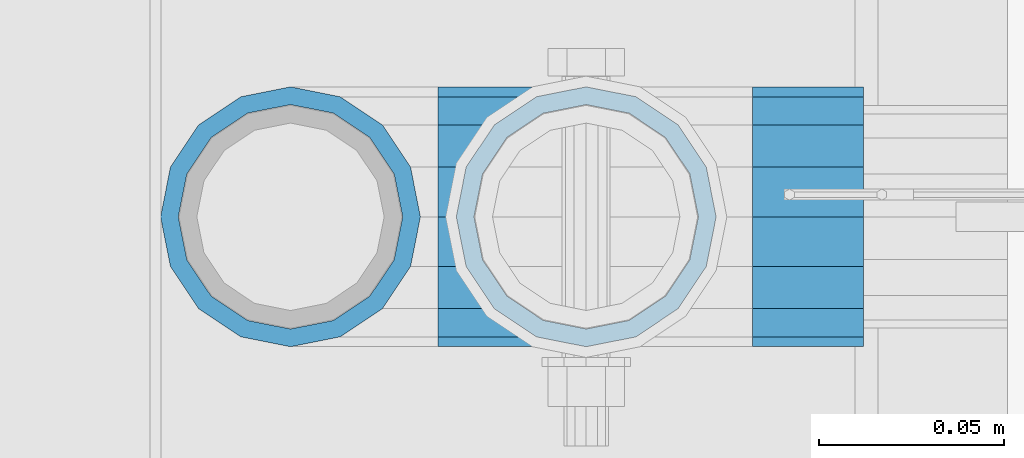
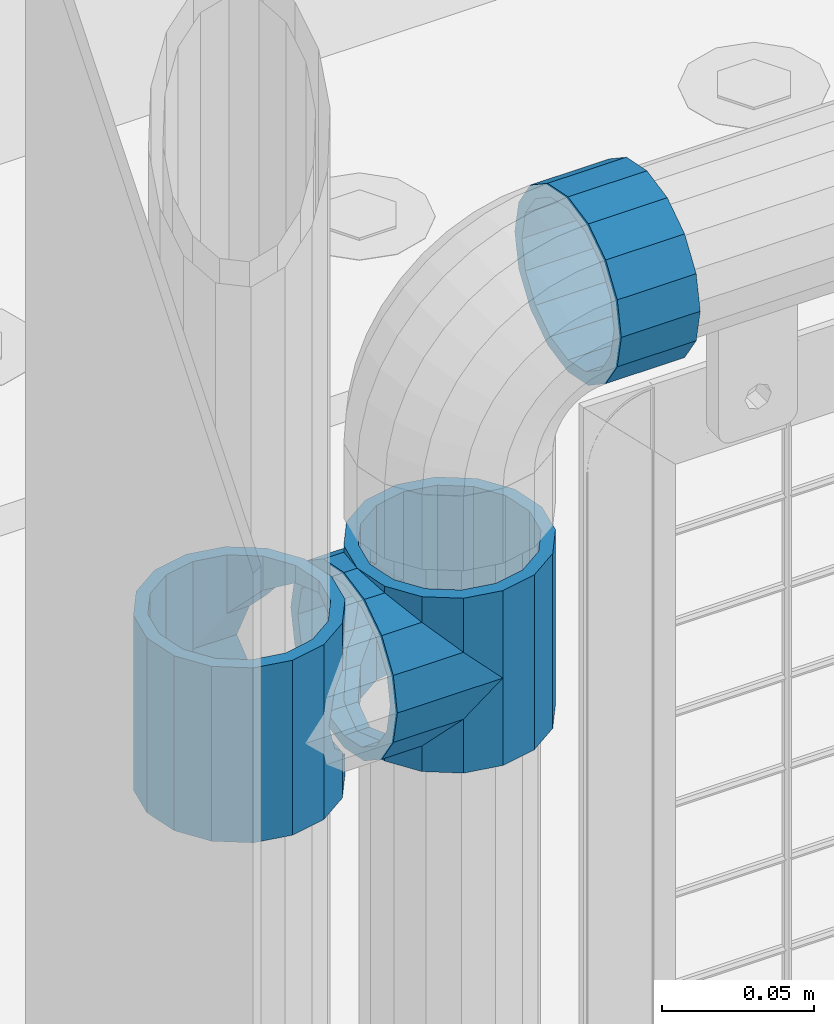
# One storey, part 134 of 219: 4 beams.
"""IFC2X3 building model written with IfcOpenShell, lengths in millimetres."""

from ifc_helpers import new_model, si_unit, frame, origin_with_axes, place, context, subcontext, project, spatial, faceted_brep, material, type_object, element, save


model = new_model("IFC2X3")

# Units and contexts
model_context = context("Model", 3, precision=1e-05, world=origin_with_axes())
body_context = subcontext(model_context, "Body", "Model", "MODEL_VIEW")
ifc_project = project(units=[si_unit("LENGTHUNIT", "METRE", prefix="MILLI"), si_unit("AREAUNIT", "SQUARE_METRE"), si_unit("VOLUMEUNIT", "CUBIC_METRE"), si_unit("MASSUNIT", "GRAM", prefix="KILO"), si_unit("TIMEUNIT", "SECOND"), si_unit("PLANEANGLEUNIT", "RADIAN"), si_unit("SOLIDANGLEUNIT", "STERADIAN"), si_unit("THERMODYNAMICTEMPERATUREUNIT", "DEGREE_CELSIUS"), si_unit("LUMINOUSINTENSITYUNIT", "LUMEN")], contexts=[model_context])

# Site, building, storey
site_placement = place(None, origin_with_axes())
site = spatial("IfcSite", under=ifc_project, at=site_placement, CompositionType="ELEMENT")
building_placement = place(site_placement, origin_with_axes())
building = spatial("IfcBuilding", under=site, at=building_placement, Name="Standard", CompositionType="ELEMENT")
storey_placement = place(building_placement, origin_with_axes())
storey = spatial("IfcBuildingStorey", under=building, at=storey_placement, Name="Undefined", CompositionType="ELEMENT", Elevation=0.0)

# Beams
ifc_material = material(Name="Misc_Undefined")
beam_type = type_object("IfcBeamType", PredefinedType="NOTDEFINED")
beam_1_placement = place(storey_placement, frame((621.0, 31664.5, 848.670000000001), z_axis=(0.0, 1.0, 0.0), x_axis=(-1.0, 0.0, 0.0)))
element("IfcBeam", 1, at=beam_1_placement, inside=storey, type_object=beam_type, material=ifc_material, context=body_context, shape_type="Brep", body=[
    faceted_brep([(0.0, 0.0, -35.1500000000015), (13.4513226476338, -13.4513226476329, -32.4743655677703), (13.4513226476338, 13.4513226476329, -32.4743655677703), (27.1226768591096, -21.4606908090117, 21.46069080901), (32.4743655677721, -26.8123795176755, 13.4513226476338), (32.4743655677721, -32.4743655677717, 13.4513226476338), (24.8548033587067, -24.8548033587072, 24.8548033587067), (24.8548033587067, -16.3810424080013, 24.8548033587067), (32.8397438117172, -28.0397438117175, 11.614442172282), (35.1499999999996, -30.35, 0.0), (35.1499999999996, -35.15, 0.0), (32.4743655677721, -26.8123795176712, -13.4513226476338), (32.4743655677721, -32.4743655677717, -13.4513226476338), (32.8397438117172, -28.0397438117175, -11.614442172282), (24.8548033587067, -16.3810424080013, -24.8548033587067), (24.8548033587067, -24.8548033587072, -24.8548033587067), (27.1226768591077, -21.4606908090117, -21.46069080901), (20.0882031229739, -11.6144421722805, -28.0397438117179), (16.6306603983649, 0.0, -30.3499999999985), (20.0882031229739, 11.6144421722805, -28.0397438117179), (24.8548033587067, 16.3810424080013, -24.8548033587067), (24.8548033587067, 24.8548033587072, -24.8548033587067), (27.1226768591077, 21.4606908090117, -21.46069080901), (32.4743655677721, 26.8123795176755, -13.4513226476338), (32.4743655677721, 32.4743655677717, -13.4513226476338), (32.8397438117172, 28.0397438117175, -11.614442172282), (35.1499999999996, 30.35, 0.0), (35.1499999999996, 35.15, 0.0), (32.8397438117172, 28.0397438117175, 11.614442172282), (32.4743655677721, 26.8123795176755, 13.4513226476338), (32.4743655677721, 32.4743655677717, 13.4513226476338), (27.1226768591096, 21.4606908090117, 21.46069080901), (24.8548033587067, 16.3810424080078, 24.8548033587067), (24.8548033587067, 24.8548033587072, 24.8548033587067), (0.0, 0.0, 35.1500000000015), (13.4513226476338, 13.4513226476329, 32.4743655677703), (13.4513226476338, -13.4513226476329, 32.4743655677703), (20.0882031229849, 11.6144421722805, 28.0397438117179), (16.6306603983739, 0.0, 30.3499999999985), (20.0882031229849, -11.6144421722805, 28.0397438117179), (40.1500000000015, -35.15, 0.0), (40.1500000000015, -32.4743655677717, 13.4513226476338), (40.1500000000015, -24.8548033587072, 24.8548033587067), (40.1500000000015, -13.4513226476329, 32.4743655677703), (40.1500000000015, 0.0, 35.1500000000015), (40.1500000000015, -24.8548033587072, -24.8548033587067), (40.1500000000015, -32.4743655677717, -13.4513226476338), (40.1500000000015, -13.4513226476329, -32.4743655677703), (40.1500000000015, 0.0, -35.1500000000015), (40.1500000000015, 13.4513226476329, -32.4743655677703), (40.1500000000015, 24.8548033587072, -24.8548033587067), (40.1500000000015, 32.4743655677717, -13.4513226476338), (40.1500000000015, 35.15, 0.0), (40.1500000000015, 32.4743655677717, 13.4513226476338), (40.1500000000015, 24.8548033587072, 24.8548033587067), (40.1500000000015, 13.4513226476329, 32.4743655677703), (40.1500000000015, -21.4606908090117, 21.46069080901), (40.1500000000015, -11.6144421722805, 28.0397438117179), (40.1500000000015, 0.0, 30.3499999999985), (40.1500000000015, 11.6144421722805, 28.0397438117179), (40.1500000000015, 21.4606908090117, 21.46069080901), (40.1500000000015, 28.0397438117175, 11.614442172282), (40.1500000000015, 30.35, 0.0), (40.1500000000015, 28.0397438117175, -11.614442172282), (40.1500000000015, 21.4606908090117, -21.46069080901), (40.1500000000015, 11.6144421722805, -28.0397438117179), (40.1500000000015, 0.0, -30.3499999999985), (40.1500000000015, -11.6144421722805, -28.0397438117179), (40.1500000000015, -21.4606908090117, -21.46069080901), (40.1500000000015, -28.0397438117175, -11.614442172282), (40.1500000000015, -30.35, 0.0), (40.1500000000015, -28.0397438117175, 11.614442172282)], [[[0, 1, 2]], [[3, 4, 5, 6, 7]], [[8, 9, 10, 5, 4]], [[11, 12, 10, 9, 13]], [[14, 15, 12, 11, 16]], [[2, 1, 15, 14, 17, 18, 19, 20, 21]], [[21, 20, 22, 23, 24]], [[24, 23, 25, 26, 27]], [[27, 26, 28, 29, 30]], [[30, 29, 31, 32, 33]], [[34, 35, 36]], [[33, 32, 37, 38, 39, 7, 6, 36, 35]], [[40, 41, 5, 10]], [[41, 42, 6, 5]], [[42, 43, 36, 6]], [[43, 44, 34, 36]], [[45, 46, 12, 15]], [[47, 45, 15, 1]], [[48, 47, 1, 0]], [[49, 48, 0, 2]], [[50, 49, 2, 21]], [[51, 50, 21, 24]], [[52, 51, 24, 27]], [[53, 52, 27, 30]], [[54, 53, 30, 33]], [[55, 54, 33, 35]], [[44, 55, 35, 34]], [[46, 40, 10, 12]], [[45, 47, 48, 49, 50, 51, 52, 53, 54, 55, 44, 43, 42, 41, 40, 46], [56, 57, 58, 59, 60, 61, 62, 63, 64, 65, 66, 67, 68, 69, 70, 71]], [[59, 58, 38, 37]], [[60, 59, 37, 32, 31]], [[61, 60, 31, 29, 28]], [[62, 61, 28, 26]], [[63, 62, 26, 25]], [[22, 64, 63, 25, 23]], [[19, 65, 64, 22, 20]], [[66, 65, 19, 18]], [[67, 66, 18, 17]], [[68, 67, 17, 14, 16]], [[69, 68, 16, 11, 13]], [[70, 69, 13, 9]], [[71, 70, 9, 8]], [[3, 56, 71, 8, 4]], [[39, 57, 56, 3, 7]], [[58, 57, 39, 38]]]),
])
beam_2_placement = place(storey_placement, frame((541.0, 31664.5, 883.820000000001), z_axis=(-1.0, 0.0, 0.0), x_axis=(0.0, 0.0, -1.0)))
element("IfcBeam", 2, at=beam_2_placement, inside=storey, type_object=beam_type, material=ifc_material, context=body_context, shape_type="Brep", body=[
    faceted_brep([(13.6893091909879, -21.46069080901, -21.4606908090118), (13.6893091909879, -21.46069080901, -27.1226768591077), (8.33762048232455, -13.4513226476338, -32.4743655677721), (7.11025618828211, -11.614442172282, -32.839743811719), (7.11025618828211, -11.614442172282, -28.0397438117179), (23.5355578277191, -28.0397438117179, -11.6144421722802), (23.5355578277191, -28.0397438117179, -20.0882031229739), (18.7689575919921, -24.8548033587067, -24.8548033587067), (35.1499999999996, -30.35, 0.0), (35.1499999999996, -30.3499999999985, -16.6306603983649), (46.7644421722801, -28.0397438117179, -11.6144421722802), (46.7644421722801, -28.0397438117179, -20.0882031229739), (56.6106908090114, -21.46069080901, -21.4606908090118), (56.6106908090114, -21.46069080901, -27.1226768591077), (51.5310424080006, -24.8548033587067, -24.8548033587067), (63.1897438117172, -11.614442172282, -28.0397438117179), (63.1897438117172, -11.614442172282, -32.839743811719), (61.9623795176747, -13.4513226476338, -32.4743655677721), (65.4999999999997, 0.0, -30.3500000000004), (65.4999999999997, 0.0, -35.1499999999996), (63.1897438117172, 11.614442172282, -28.0397438117179), (63.1897438117172, 11.614442172282, -32.8397438117172), (56.6106908090114, 21.46069080901, -21.4606908090118), (56.6106908090114, 21.46069080901, -27.1226768591096), (61.9623795176703, 13.4513226476338, -32.4743655677721), (46.7644421722801, 28.0397438117179, -11.6144421722802), (46.7644421722801, 28.0397438117179, -20.0882031229849), (51.5310424080006, 24.8548033587067, -24.8548033587067), (35.1499999999996, 30.35, 0.0), (35.1499999999996, 30.3499999999985, -16.6306603983739), (23.5355578277192, 28.0397438117179, -11.6144421722802), (23.5355578277192, 28.0397438117179, -20.0882031229849), (13.6893091909879, 21.46069080901, -21.4606908090118), (13.6893091909879, 21.46069080901, -27.1226768591096), (18.7689575919987, 24.8548033587067, -24.8548033587067), (7.11025618828211, 11.614442172282, -28.0397438117179), (7.11025618828211, 11.614442172282, -32.8397438117172), (8.33762048232455, 13.4513226476338, -32.4743655677721), (4.79999999999961, 0.0, -30.3500000000004), (4.79999999999961, 0.0, -35.1499999999996), (0.0, 21.46069080901, 21.4606908090118), (0.0, 28.0397438117179, 11.6144421722802), (70.2999999999993, 28.0397438117179, 11.6144421722802), (70.2999999999993, 21.46069080901, 21.4606908090118), (0.0, 11.614442172282, 28.0397438117179), (70.2999999999993, 11.614442172282, 28.0397438117179), (0.0, 0.0, 30.3500000000004), (70.2999999999993, 0.0, 30.3500000000004), (0.0, -11.614442172282, 28.0397438117179), (70.2999999999993, -11.614442172282, 28.0397438117179), (0.0, -21.46069080901, 21.4606908090118), (70.2999999999993, -21.46069080901, 21.4606908090118), (0.0, -28.0397438117179, 11.6144421722802), (70.2999999999993, -28.0397438117179, 11.6144421722802), (0.0, -24.8548033587067, -24.8548033587067), (0.0, -13.4513226476338, -32.4743655677721), (0.0, 0.0, -35.1500000000015), (0.0, -32.4743655677703, 13.4513226476338), (0.0, -35.1500000000015, 0.0), (70.2999999999993, -35.1500000000015, 0.0), (70.2999999999993, -32.4743655677703, 13.4513226476338), (0.0, -24.8548033587067, 24.8548033587067), (70.2999999999993, -24.8548033587067, 24.8548033587067), (0.0, -13.4513226476338, 32.4743655677721), (70.2999999999993, -13.4513226476338, 32.4743655677721), (0.0, 0.0, 35.1500000000015), (70.2999999999993, 0.0, 35.1499999999996), (0.0, 13.4513226476338, 32.4743655677721), (70.2999999999993, 13.4513226476338, 32.4743655677721), (0.0, 24.8548033587067, 24.8548033587067), (70.2999999999993, 24.8548033587067, 24.8548033587067), (0.0, 32.4743655677703, 13.4513226476338), (70.2999999999993, 32.4743655677703, 13.4513226476338), (0.0, 35.1500000000015, 0.0), (70.2999999999993, 35.1500000000015, 0.0), (0.0, 32.4743655677703, -13.4513226476338), (70.2999999999993, 32.4743655677703, -13.4513226476338), (70.2999999999993, -13.4513226476338, -32.4743655677721), (70.2999999999993, -24.8548033587067, -24.8548033587067), (70.2999999999993, 0.0, -35.1499999999996), (70.2999999999993, 13.4513226476338, -32.4743655677721), (70.2999999999993, 24.8548033587067, -24.8548033587067), (0.0, 24.8548033587067, -24.8548033587067), (0.0, 13.4513226476338, -32.4743655677721), (70.2999999999993, -32.4743655677703, -13.4513226476338), (0.0, -32.4743655677703, -13.4513226476338), (0.0, -28.0397438117179, -11.6144421722802), (0.0, -21.46069080901, -21.4606908090118), (0.0, -11.614442172282, -28.0397438117179), (0.0, 0.0, -30.3500000000004), (0.0, 11.614442172282, -28.0397438117179), (0.0, 21.46069080901, -21.4606908090118), (0.0, 28.0397438117179, -11.6144421722802), (0.0, 30.3499999999985, 0.0), (0.0, -30.3499999999985, 0.0), (70.2999999999993, 30.3499999999985, 0.0), (70.2999999999993, 28.0397438117179, -11.6144421722802), (70.2999999999993, 21.46069080901, -21.4606908090118), (70.2999999999993, 11.614442172282, -28.0397438117179), (70.2999999999993, 0.0, -30.3500000000004), (70.2999999999993, -11.614442172282, -28.0397438117179), (70.2999999999993, -21.46069080901, -21.4606908090118), (70.2999999999993, -28.0397438117179, -11.6144421722802), (70.2999999999993, -30.3499999999985, 0.0)], [[[0, 1, 2, 3, 4]], [[5, 6, 7, 1, 0]], [[8, 9, 6, 5]], [[10, 11, 9, 8]], [[12, 13, 14, 11, 10]], [[15, 16, 17, 13, 12]], [[18, 19, 16, 15]], [[20, 21, 19, 18]], [[22, 23, 24, 21, 20]], [[25, 26, 27, 23, 22]], [[28, 29, 26, 25]], [[30, 31, 29, 28]], [[32, 33, 34, 31, 30]], [[35, 36, 37, 33, 32]], [[38, 39, 36, 35]], [[4, 3, 39, 38]], [[40, 41, 42, 43]], [[44, 40, 43, 45]], [[46, 44, 45, 47]], [[48, 46, 47, 49]], [[50, 48, 49, 51]], [[52, 50, 51, 53]], [[54, 55, 2, 1, 7]], [[55, 56, 39, 3, 2]], [[57, 58, 59, 60]], [[61, 57, 60, 62]], [[63, 61, 62, 64]], [[65, 63, 64, 66]], [[67, 65, 66, 68]], [[69, 67, 68, 70]], [[71, 69, 70, 72]], [[73, 71, 72, 74]], [[75, 73, 74, 76]], [[17, 77, 78, 14, 13]], [[19, 79, 77, 17, 16]], [[80, 79, 19, 21, 24]], [[81, 80, 24, 23, 27]], [[34, 82, 75, 76, 81, 27, 26, 29, 31]], [[37, 83, 82, 34, 33]], [[39, 56, 83, 37, 36]], [[14, 78, 84, 85, 54, 7, 6, 9, 11]], [[58, 85, 84, 59]], [[57, 61, 63, 65, 67, 69, 71, 73, 75, 82, 83, 56, 55, 54, 85, 58], [86, 87, 88, 89, 90, 91, 92, 93, 41, 40, 44, 46, 48, 50, 52, 94]], [[90, 89, 38, 35]], [[91, 90, 35, 32]], [[92, 91, 32, 30]], [[93, 92, 30, 28]], [[41, 93, 28, 95, 42]], [[96, 95, 28, 25]], [[97, 96, 25, 22]], [[98, 97, 22, 20]], [[99, 98, 20, 18]], [[100, 99, 18, 15]], [[101, 100, 15, 12]], [[102, 101, 12, 10]], [[103, 102, 10, 8]], [[78, 77, 79, 80, 81, 76, 74, 72, 70, 68, 66, 64, 62, 60, 59, 84], [51, 49, 47, 45, 43, 42, 95, 96, 97, 98, 99, 100, 101, 102, 103, 53]], [[8, 94, 52, 53, 103]], [[86, 94, 8, 5]], [[87, 86, 5, 0]], [[88, 87, 0, 4]], [[89, 88, 4, 38]]]),
])
beam_3_placement = place(storey_placement, frame((621.0, 31664.5, 883.820000000001), z_axis=(1.0, 0.0, 0.0), x_axis=(0.0, 0.0, -1.0)))
element("IfcBeam", 3, at=beam_3_placement, inside=storey, type_object=beam_type, material=ifc_material, context=body_context, shape_type="Brep", body=[
    faceted_brep([(46.7644421722801, 28.0397438117179, -11.6144421722802), (46.7644421722801, 28.0397438117179, -20.0882031229849), (51.5310424080006, 24.8548033587067, -24.8548033587067), (56.6106908090114, 21.46069080901, -27.1226768591096), (56.6106908090114, 21.46069080901, -21.4606908090118), (61.9623795176703, 13.4513226476338, -32.4743655677721), (63.1897438117172, 11.614442172282, -32.8397438117172), (63.1897438117172, 11.614442172282, -28.0397438117179), (65.4999999999997, 0.0, -35.1499999999996), (65.4999999999997, 0.0, -30.3500000000004), (63.1897438117172, -11.614442172282, -32.839743811719), (63.1897438117172, -11.614442172282, -28.0397438117179), (61.9623795176747, -13.4513226476338, -32.4743655677721), (56.6106908090114, -21.46069080901, -27.1226768591077), (56.6106908090114, -21.46069080901, -21.4606908090118), (51.5310424080006, -24.8548033587067, -24.8548033587067), (46.7644421722801, -28.0397438117179, -20.0882031229739), (46.7644421722801, -28.0397438117179, -11.6144421722802), (35.1499999999996, -30.3499999999985, -16.6306603983649), (35.1499999999996, -30.35, 0.0), (23.5355578277191, -28.0397438117179, -20.0882031229739), (23.5355578277191, -28.0397438117179, -11.6144421722802), (18.7689575919921, -24.8548033587067, -24.8548033587067), (13.6893091909879, -21.46069080901, -27.1226768591077), (13.6893091909879, -21.46069080901, -21.4606908090118), (8.33762048232455, -13.4513226476338, -32.4743655677721), (7.11025618828211, -11.614442172282, -32.839743811719), (7.11025618828211, -11.614442172282, -28.0397438117179), (4.79999999999961, 0.0, -35.1499999999996), (4.79999999999961, 0.0, -30.3500000000004), (7.11025618828211, 11.614442172282, -32.8397438117172), (7.11025618828211, 11.614442172282, -28.0397438117179), (8.33762048232455, 13.4513226476338, -32.4743655677721), (13.6893091909879, 21.46069080901, -27.1226768591096), (13.6893091909879, 21.46069080901, -21.4606908090118), (18.7689575919987, 24.8548033587067, -24.8548033587067), (23.5355578277192, 28.0397438117179, -20.0882031229849), (23.5355578277192, 28.0397438117179, -11.6144421722802), (35.1499999999996, 30.3499999999985, -16.6306603983739), (35.1499999999996, 30.35, 0.0), (0.0, 32.4743655677703, -13.4513226476338), (0.0, 35.1500000000015, 0.0), (70.2999999999993, 35.1500000000015, 0.0), (70.2999999999993, 32.4743655677703, -13.4513226476338), (0.0, 32.4743655677703, 13.4513226476338), (70.2999999999993, 32.4743655677703, 13.4513226476338), (0.0, 24.8548033587067, 24.8548033587067), (70.2999999999993, 24.8548033587067, 24.8548033587067), (0.0, 13.4513226476338, 32.4743655677721), (70.2999999999993, 13.4513226476338, 32.4743655677721), (0.0, 0.0, 35.1500000000015), (70.2999999999993, 0.0, 35.1499999999996), (0.0, -13.4513226476338, 32.4743655677721), (70.2999999999993, -13.4513226476338, 32.4743655677721), (0.0, -24.8548033587067, 24.8548033587067), (70.2999999999993, -24.8548033587067, 24.8548033587067), (0.0, -32.4743655677703, 13.4513226476338), (70.2999999999993, -32.4743655677703, 13.4513226476338), (0.0, -35.1500000000015, 0.0), (70.2999999999993, -35.1500000000015, 0.0), (70.2999999999993, -30.3499999999985, 0.0), (70.2999999999993, -28.0397438117179, -11.6144421722802), (70.2999999999993, -21.46069080901, -21.4606908090118), (70.2999999999993, -11.614442172282, -28.0397438117179), (70.2999999999993, 0.0, -30.3500000000004), (70.2999999999993, 11.614442172282, -28.0397438117179), (70.2999999999993, 21.46069080901, -21.4606908090118), (70.2999999999993, 28.0397438117179, -11.6144421722802), (0.0, -28.0397438117179, -11.6144421722802), (0.0, -30.3499999999985, 0.0), (0.0, -21.46069080901, -21.4606908090118), (0.0, -11.614442172282, -28.0397438117179), (0.0, 0.0, -30.3500000000004), (0.0, 11.614442172282, -28.0397438117179), (0.0, 21.46069080901, -21.4606908090118), (0.0, 28.0397438117179, -11.6144421722802), (0.0, 30.3499999999985, 0.0), (70.2999999999993, 30.3499999999985, 0.0), (0.0, 28.0397438117179, 11.6144421722802), (70.2999999999993, 28.0397438117179, 11.6144421722802), (0.0, 21.46069080901, 21.4606908090118), (70.2999999999993, 21.46069080901, 21.4606908090118), (0.0, 11.614442172282, 28.0397438117179), (70.2999999999993, 11.614442172282, 28.0397438117179), (0.0, 0.0, 30.3500000000004), (70.2999999999993, 0.0, 30.3500000000004), (0.0, -11.614442172282, 28.0397438117179), (70.2999999999993, -11.614442172282, 28.0397438117179), (0.0, -21.46069080901, 21.4606908090118), (70.2999999999993, -21.46069080901, 21.4606908090118), (0.0, -28.0397438117179, 11.6144421722802), (70.2999999999993, -28.0397438117179, 11.6144421722802), (70.2999999999993, -24.8548033587067, -24.8548033587067), (70.2999999999993, -13.4513226476338, -32.4743655677721), (70.2999999999993, 0.0, -35.1499999999996), (70.2999999999993, 13.4513226476338, -32.4743655677721), (70.2999999999993, 24.8548033587067, -24.8548033587067), (70.2999999999993, -32.4743655677703, -13.4513226476338), (0.0, -32.4743655677703, -13.4513226476338), (0.0, 24.8548033587067, -24.8548033587067), (0.0, 13.4513226476338, -32.4743655677721), (0.0, 0.0, -35.1500000000015), (0.0, -13.4513226476338, -32.4743655677721), (0.0, -24.8548033587067, -24.8548033587067)], [[[0, 1, 2, 3, 4]], [[4, 3, 5, 6, 7]], [[7, 6, 8, 9]], [[9, 8, 10, 11]], [[11, 10, 12, 13, 14]], [[14, 13, 15, 16, 17]], [[17, 16, 18, 19]], [[19, 18, 20, 21]], [[21, 20, 22, 23, 24]], [[24, 23, 25, 26, 27]], [[27, 26, 28, 29]], [[29, 28, 30, 31]], [[31, 30, 32, 33, 34]], [[34, 33, 35, 36, 37]], [[37, 36, 38, 39]], [[39, 38, 1, 0]], [[40, 41, 42, 43]], [[41, 44, 45, 42]], [[44, 46, 47, 45]], [[46, 48, 49, 47]], [[48, 50, 51, 49]], [[50, 52, 53, 51]], [[52, 54, 55, 53]], [[54, 56, 57, 55]], [[56, 58, 59, 57]], [[60, 61, 17, 19]], [[61, 62, 14, 17]], [[62, 63, 11, 14]], [[63, 64, 9, 11]], [[64, 65, 7, 9]], [[65, 66, 4, 7]], [[66, 67, 0, 4]], [[68, 69, 19, 21]], [[70, 68, 21, 24]], [[71, 70, 24, 27]], [[72, 71, 27, 29]], [[73, 72, 29, 31]], [[74, 73, 31, 34]], [[75, 74, 34, 37]], [[76, 75, 37, 39]], [[67, 77, 39, 0]], [[78, 76, 39, 77, 79]], [[80, 78, 79, 81]], [[82, 80, 81, 83]], [[84, 82, 83, 85]], [[86, 84, 85, 87]], [[88, 86, 87, 89]], [[90, 88, 89, 91]], [[19, 69, 90, 91, 60]], [[92, 93, 94, 95, 96, 43, 42, 45, 47, 49, 51, 53, 55, 57, 59, 97], [89, 87, 85, 83, 81, 79, 77, 67, 66, 65, 64, 63, 62, 61, 60, 91]], [[58, 98, 97, 59]], [[56, 54, 52, 50, 48, 46, 44, 41, 40, 99, 100, 101, 102, 103, 98, 58], [68, 70, 71, 72, 73, 74, 75, 76, 78, 80, 82, 84, 86, 88, 90, 69]], [[32, 100, 99, 35, 33]], [[28, 101, 100, 32, 30]], [[102, 101, 28, 26, 25]], [[103, 102, 25, 23, 22]], [[15, 92, 97, 98, 103, 22, 20, 18, 16]], [[12, 93, 92, 15, 13]], [[8, 94, 93, 12, 10]], [[95, 94, 8, 6, 5]], [[96, 95, 5, 3, 2]], [[35, 99, 40, 43, 96, 2, 1, 38, 36]]]),
])
beam_4_placement = place(storey_placement, frame((666.0, 31664.5, 969.849999999999), z_axis=(0.0, 0.0, 1.0), x_axis=(1.0, 0.0, 0.0)))
element("IfcBeam", 4, at=beam_4_placement, inside=storey, type_object=beam_type, material=ifc_material, context=body_context, shape_type="Brep", body=[
    faceted_brep([(0.0, -30.3499999999985, 0.0), (0.0, -28.0397438117179, 11.6144421722802), (30.0, -28.0397438117179, 11.6144421722805), (30.0, -30.3499999999985, 0.0), (0.0, -21.46069080901, 21.4606908090118), (30.0, -21.46069080901, 21.4606908090117), (0.0, -11.614442172282, 28.0397438117179), (30.0, -11.614442172282, 28.0397438117176), (0.0, 0.0, 30.3500000000004), (30.0, 0.0, 30.35), (0.0, 11.614442172282, 28.0397438117179), (30.0, 11.614442172282, 28.0397438117176), (0.0, 21.46069080901, 21.4606908090118), (30.0, 21.46069080901, 21.4606908090117), (0.0, 28.0397438117179, 11.6144421722802), (30.0, 28.0397438117179, 11.6144421722805), (0.0, 30.3499999999985, 0.0), (30.0, 30.3499999999985, 0.0), (0.0, 28.0397438117179, -11.6144421722802), (30.0, 28.0397438117179, -11.6144421722805), (0.0, 21.46069080901, -21.4606908090118), (30.0, 21.46069080901, -21.4606908090117), (0.0, 11.614442172282, -28.0397438117179), (30.0, 11.614442172282, -28.0397438117176), (0.0, 0.0, -30.3500000000004), (30.0, 0.0, -30.35), (0.0, -11.614442172282, -28.0397438117179), (30.0, -11.614442172282, -28.0397438117176), (0.0, -21.46069080901, -21.4606908090118), (30.0, -21.46069080901, -21.4606908090117), (0.0, -28.0397438117179, -11.6144421722802), (30.0, -28.0397438117179, -11.6144421722805), (0.0, -35.1500000000015, 0.0), (0.0, -32.4743655677703, -13.4513226476338), (30.0, -32.4743655677703, -13.4513226476329), (30.0, -35.1500000000015, 0.0), (0.0, -24.8548033587067, -24.8548033587067), (30.0, -24.8548033587067, -24.8548033587072), (0.0, -13.4513226476338, -32.4743655677721), (30.0, -13.4513226476338, -32.4743655677718), (0.0, 0.0, -35.1500000000015), (30.0, 0.0, -35.15), (0.0, 13.4513226476338, -32.4743655677721), (30.0, 13.4513226476338, -32.4743655677718), (0.0, 24.8548033587067, -24.8548033587067), (30.0, 24.8548033587067, -24.8548033587072), (0.0, 32.4743655677703, -13.4513226476338), (30.0, 32.4743655677703, -13.4513226476329), (0.0, 35.1500000000015, 0.0), (30.0, 35.1500000000015, 0.0), (0.0, 32.4743655677703, 13.4513226476338), (30.0, 32.4743655677703, 13.4513226476329), (0.0, 24.8548033587067, 24.8548033587067), (30.0, 24.8548033587067, 24.8548033587072), (0.0, 13.4513226476338, 32.4743655677721), (30.0, 13.4513226476338, 32.4743655677718), (0.0, 0.0, 35.1500000000015), (30.0, 0.0, 35.15), (0.0, -13.4513226476338, 32.4743655677721), (30.0, -13.4513226476338, 32.4743655677718), (0.0, -24.8548033587067, 24.8548033587067), (30.0, -24.8548033587067, 24.8548033587072), (0.0, -32.4743655677703, 13.4513226476338), (30.0, -32.4743655677703, 13.4513226476329)], [[[0, 1, 2, 3]], [[1, 4, 5, 2]], [[4, 6, 7, 5]], [[6, 8, 9, 7]], [[8, 10, 11, 9]], [[10, 12, 13, 11]], [[12, 14, 15, 13]], [[14, 16, 17, 15]], [[16, 18, 19, 17]], [[18, 20, 21, 19]], [[20, 22, 23, 21]], [[22, 24, 25, 23]], [[24, 26, 27, 25]], [[26, 28, 29, 27]], [[28, 30, 31, 29]], [[30, 0, 3, 31]], [[32, 33, 34, 35]], [[33, 36, 37, 34]], [[36, 38, 39, 37]], [[38, 40, 41, 39]], [[40, 42, 43, 41]], [[42, 44, 45, 43]], [[44, 46, 47, 45]], [[46, 48, 49, 47]], [[48, 50, 51, 49]], [[50, 52, 53, 51]], [[52, 54, 55, 53]], [[54, 56, 57, 55]], [[56, 58, 59, 57]], [[58, 60, 61, 59]], [[60, 62, 63, 61]], [[62, 32, 35, 63]], [[37, 39, 41, 43, 45, 47, 49, 51, 53, 55, 57, 59, 61, 63, 35, 34], [5, 7, 9, 11, 13, 15, 17, 19, 21, 23, 25, 27, 29, 31, 3, 2]], [[62, 60, 58, 56, 54, 52, 50, 48, 46, 44, 42, 40, 38, 36, 33, 32], [30, 28, 26, 24, 22, 20, 18, 16, 14, 12, 10, 8, 6, 4, 1, 0]]]),
])

save(model, "model.ifc")
